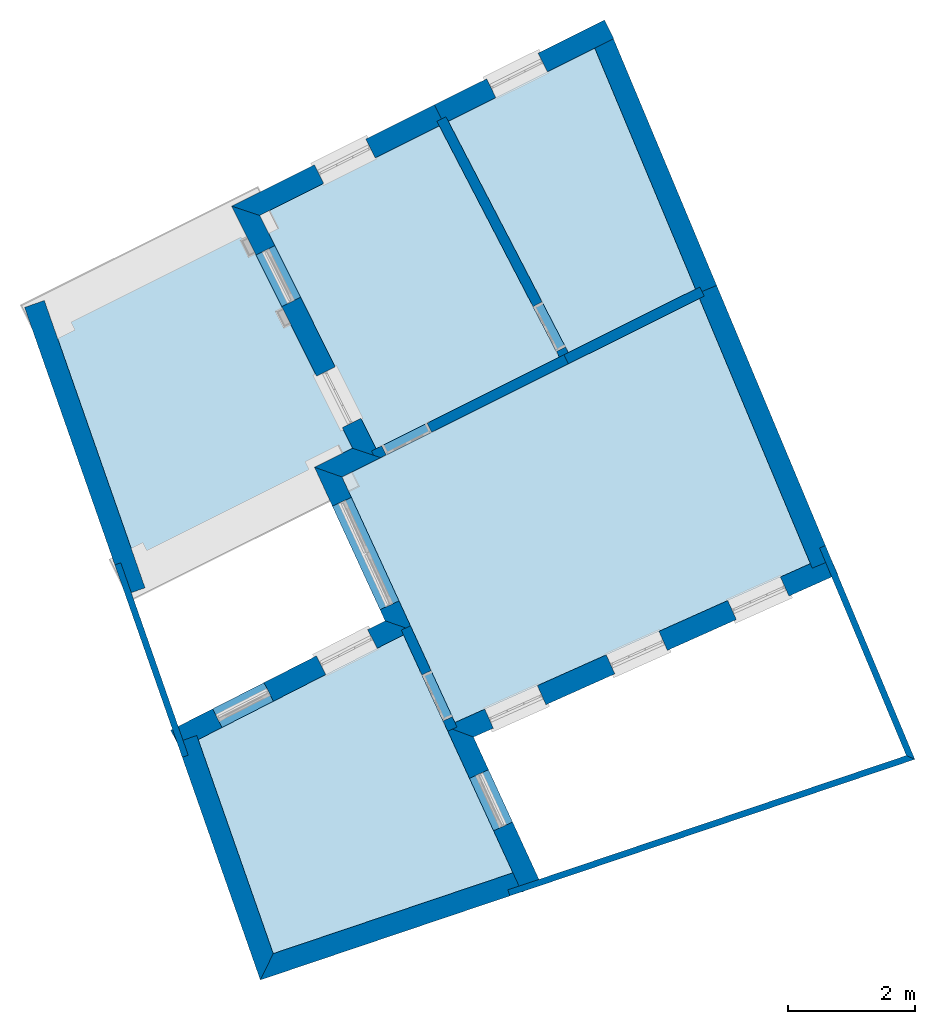
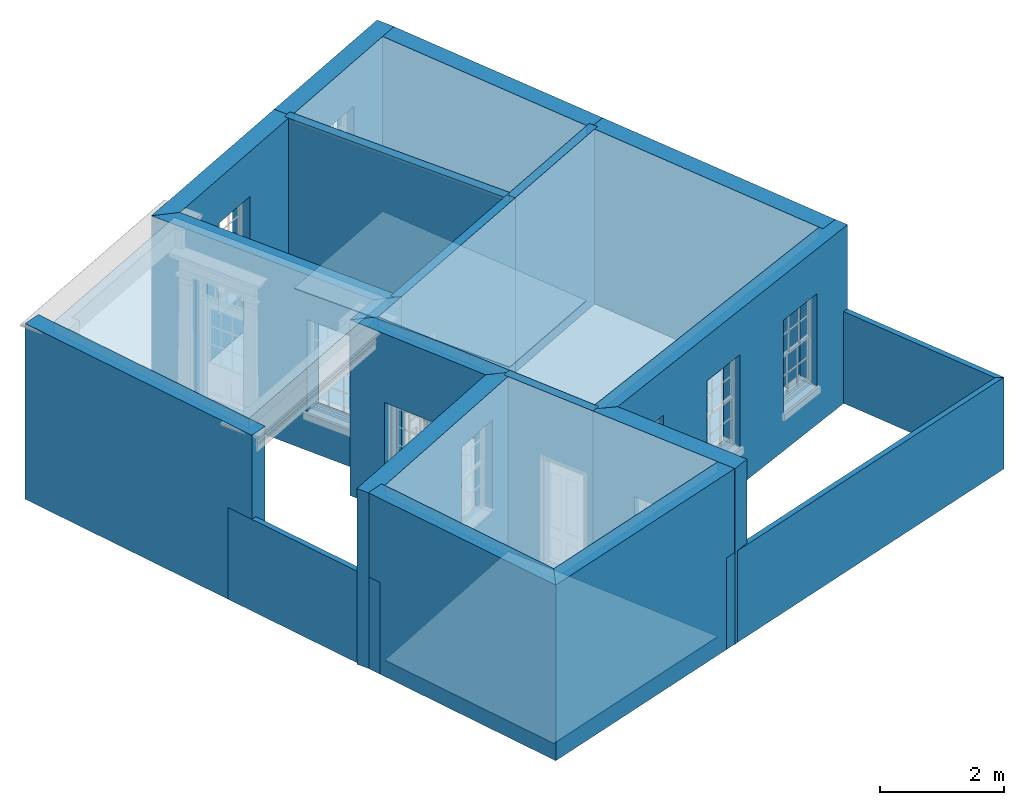
# One storey, part 1 of 10: 20 walls, 8 slabs, 14 openings.
"""IFC2X3 building model written with IfcOpenShell, lengths in metres."""

import ifcopenshell
import ifcopenshell.guid

model = None  # the IFC model being written
_history = None  # IfcOwnerHistory: only IFC2X3 demands one
_inside = {}  # id of a spatial element -> (the spatial element, [elements in it])
_under = {}  # id of a project, library or spatial element -> (it, [spatial elements below it])
_declared = {}  # id of a project -> (the project, [libraries it declares])
_typed = {}  # id of a type object -> (the type object, [elements of that type])
_made_of = {}  # id of a material, layer set ... -> (it, [elements and type objects made of it])


def new_model(schema):
    """Start an empty IFC model of exactly this schema.

    Asked for "IFC4X3", IfcOpenShell would pick the latest addendum, in which some entities
    have other attributes; the version numbers below select the first issue.
    IFC2X3 requires an IfcOwnerHistory on every rooted entity: one is made here for all.
    """
    global model, _history
    if schema == "IFC4X3":
        model = ifcopenshell.file(schema_version=(4, 3, 0, 0))
    else:
        model = ifcopenshell.file(schema=schema)
    _inside.clear()
    _under.clear()
    _declared.clear()
    _typed.clear()
    _made_of.clear()
    _history = None
    if model.schema == "IFC2X3":
        org = make("IfcOrganization", Name="unknown")
        user = make(
            "IfcPersonAndOrganization",
            ThePerson=make("IfcPerson", FamilyName="unknown"),
            TheOrganization=org,
        )
        app = make(
            "IfcApplication",
            ApplicationDeveloper=org,
            Version="unknown",
            ApplicationFullName="unknown",
            ApplicationIdentifier="unknown",
        )
        _history = make(
            "IfcOwnerHistory",
            OwningUser=user,
            OwningApplication=app,
            ChangeAction="ADDED",
            CreationDate=0,
        )
    return model


def make(cls, **values):
    """One entity of the class cls with the attributes given. An attribute that is None is left unset."""
    return model.create_entity(
        cls, **{name: value for name, value in values.items() if value is not None}
    )


def rooted(cls, **values):
    """An entity with a GlobalId (a new one), such as an element, a storey or a relation."""
    return make(cls, GlobalId=ifcopenshell.guid.new(), OwnerHistory=_history, **values)


def si_unit(unit_type, name, prefix=None):
    """IfcSIUnit, for example si_unit("LENGTHUNIT", "METRE", prefix="MILLI")."""
    return make("IfcSIUnit", UnitType=unit_type, Prefix=prefix, Name=name)


def assignment(units):
    """IfcUnitAssignment: the units of a project."""
    return None if units is None else make("IfcUnitAssignment", Units=units)


def point(xyz):
    """IfcCartesianPoint."""
    return None if xyz is None else make("IfcCartesianPoint", Coordinates=xyz)


def direction(xyz):
    """IfcDirection."""
    return None if xyz is None else make("IfcDirection", DirectionRatios=xyz)


def frame(location, z_axis=None, x_axis=None):
    """IfcAxis2Placement3D, a coordinate frame: its origin and axes. An axis left out is left unset."""
    return make(
        "IfcAxis2Placement3D",
        Location=point(location),
        Axis=direction(z_axis),
        RefDirection=direction(x_axis),
    )


def origin():
    """The frame at (0, 0, 0) with its axes left unset."""
    return frame((0.0, 0.0, 0.0))


def place(relative_to, where):
    """IfcLocalPlacement: puts the frame where relative to a parent placement (None: the world)."""
    return make(
        "IfcLocalPlacement", PlacementRelTo=relative_to, RelativePlacement=where
    )


def context(
    kind, dimensions, precision=None, world=None, true_north=None, identifier=None
):
    """IfcGeometricRepresentationContext, for example the 3D "Model" context."""
    return make(
        "IfcGeometricRepresentationContext",
        ContextIdentifier=identifier,
        ContextType=kind,
        CoordinateSpaceDimension=dimensions,
        Precision=precision,
        WorldCoordinateSystem=world,
        TrueNorth=true_north,
    )


def subcontext(parent, identifier, kind, view, scale=None):
    """IfcGeometricRepresentationSubContext, for example "Body" below "Model"."""
    return make(
        "IfcGeometricRepresentationSubContext",
        ContextIdentifier=identifier,
        ContextType=kind,
        ParentContext=parent,
        TargetScale=scale,
        TargetView=view,
    )


def project(units=None, contexts=None):
    """IfcProject with its units and contexts."""
    return rooted(
        "IfcProject",
        Name="project",
        RepresentationContexts=contexts,
        UnitsInContext=assignment(units),
    )


def spatial(cls, under=None, at=None, **own):
    """A site, building, storey or space (cls), placed at a placement, below another one or the project."""
    s = rooted(cls, ObjectPlacement=at, **own)
    if under is not None:
        _under.setdefault(under.id(), (under, []))[1].append(s)
    return s


def polyline(points):
    """IfcPolyline through the points."""
    return make("IfcPolyline", Points=[point(p) for p in points])


def outline(outer, holes=None, kind="AREA"):
    """IfcArbitraryClosedProfileDef: a profile drawn as a closed curve; with holes, ...WithVoids."""
    if holes is None:
        return make("IfcArbitraryClosedProfileDef", ProfileType=kind, OuterCurve=outer)
    return make(
        "IfcArbitraryProfileDefWithVoids",
        ProfileType=kind,
        OuterCurve=outer,
        InnerCurves=holes,
    )


def extrude(swept, where, along, depth):
    """IfcExtrudedAreaSolid: the profile swept, set in the frame where, extruded along a direction by depth."""
    return make(
        "IfcExtrudedAreaSolid",
        SweptArea=swept,
        Position=where,
        ExtrudedDirection=direction(along),
        Depth=depth,
    )


def shape(context_of_items, identifier, shape_type, items):
    """IfcShapeRepresentation: the items that make up one representation, for example the "Body"."""
    return make(
        "IfcShapeRepresentation",
        ContextOfItems=context_of_items,
        RepresentationIdentifier=identifier,
        RepresentationType=shape_type,
        Items=items,
    )


def material(Name=None, Category=None):
    """IfcMaterial."""
    return make("IfcMaterial", Name=Name, Category=Category)


def layer(
    of_material, thickness, ventilated=None, Name=None, Category=None, Priority=None
):
    """IfcMaterialLayer: one layer of a wall or slab, of a material (None: an air gap)."""
    return make(
        "IfcMaterialLayer",
        Material=of_material,
        LayerThickness=thickness,
        IsVentilated=ventilated,
        Name=Name,
        Category=Category,
        Priority=Priority,
    )


def layer_set(layers, Name=None):
    """IfcMaterialLayerSet."""
    return make("IfcMaterialLayerSet", MaterialLayers=layers, LayerSetName=Name)


def layer_usage(for_layer_set, set_direction, sense, offset, extent=None):
    """IfcMaterialLayerSetUsage: how a layer set lies in its element."""
    return make(
        "IfcMaterialLayerSetUsage",
        ForLayerSet=for_layer_set,
        LayerSetDirection=set_direction,
        DirectionSense=sense,
        OffsetFromReferenceLine=offset,
        ReferenceExtent=extent,
    )


def made_of(thing, what):
    """Note that an element or type object is made of a material, layer set ...; save() writes the relation."""
    if what is not None:
        _made_of.setdefault(what.id(), (what, []))[1].append(thing)
    return thing


def element(
    cls,
    number,
    at=None,
    inside=None,
    cuts=None,
    type_object=None,
    material=None,
    context=None,
    identifier="Body",
    shape_type=None,
    held_by="IfcProductDefinitionShape",
    body=None,
    shapes=None,
    **own,
):
    """One element of the class cls, such as IfcWall. Its Tag is "e" and its number.

    at: its placement. inside: the storey or other place that contains it. cuts: it is an
    opening in that element (IfcRelVoidsElement). A single representation is given by context,
    identifier, shape_type and body (its items); several are given by shapes. held_by: the class
    of the entity that holds the representations. save() writes the other relations.
    """
    e = rooted(cls, Tag="e%d" % number, ObjectPlacement=at, **own)
    if body is not None:
        shapes = [shape(context, identifier, shape_type, body)]
    if shapes is not None:
        e.Representation = make(held_by, Representations=shapes)
    if inside is not None:
        _inside.setdefault(inside.id(), (inside, []))[1].append(e)
    if cuts is not None:
        rooted(
            "IfcRelVoidsElement", RelatingBuildingElement=cuts, RelatedOpeningElement=e
        )
    if type_object is not None:
        _typed.setdefault(type_object.id(), (type_object, []))[1].append(e)
    return made_of(e, material)


def aggregate(whole, parts):
    """IfcRelAggregates: a whole, such as a stair, and the parts it consists of."""
    return rooted("IfcRelAggregates", RelatingObject=whole, RelatedObjects=parts)


def save(model, path):
    """Write the relations noted so far, then the file.

    IfcRelAggregates (storeys below a building ...), IfcRelContainedInSpatialStructure (elements
    in a storey), IfcRelDefinesByType, IfcRelAssociatesMaterial and IfcRelDeclares: one each for
    every whole, place, type object, material and project.
    """
    for whole, parts in _under.values():
        aggregate(whole, parts)
    for where, things in _inside.values():
        rooted(
            "IfcRelContainedInSpatialStructure",
            RelatedElements=things,
            RelatingStructure=where,
        )
    for kind, things in _typed.values():
        rooted("IfcRelDefinesByType", RelatedObjects=things, RelatingType=kind)
    for what, things in _made_of.values():
        rooted("IfcRelAssociatesMaterial", RelatedObjects=things, RelatingMaterial=what)
    for by, libraries in _declared.values():
        rooted("IfcRelDeclares", RelatingContext=by, RelatedDefinitions=libraries)
    model.write(path)


model = new_model("IFC2X3")

# Units and contexts
model_context = context("Model", 3, world=origin())
body_context = subcontext(model_context, "Body", "Model", "MODEL_VIEW")
ifc_project = project(units=[si_unit("PLANEANGLEUNIT", "RADIAN"), si_unit("MASSUNIT", "GRAM", prefix="KILO"), si_unit("FORCEUNIT", "NEWTON", prefix="KILO"), si_unit("LENGTHUNIT", "METRE")], contexts=[model_context])

# Site, building, storey
site_placement = place(None, origin())
site = spatial("IfcSite", under=ifc_project, at=site_placement, CompositionType="ELEMENT")
building_placement = place(None, origin())
building = spatial("IfcBuilding", under=site, at=building_placement, Name="Building plot-8", CompositionType="ELEMENT")
storey_placement = place(None, origin())
storey = spatial("IfcBuildingStorey", under=building, at=storey_placement, Name="Floor 0", CompositionType="ELEMENT", Elevation=0.0)

# Slabs
slab_1_placement = place(storey_placement, frame((0.0, 0.0, 3.25)))
element("IfcSlab", 1, at=slab_1_placement, inside=storey, Name="Slab", ObjectType="Slab", PredefinedType="FLOOR", context=body_context, shape_type="SweptSolid", body=[
    extrude(outline(polyline([(31.3024320418341, 11.6441148215606), (29.5509227560087, 15.8319749374872), (23.9047363507031, 13.0131514717753), (25.6887883842839, 9.13469885839309), (31.3024320418341, 11.6441148215606)])), origin(), (0.0, 0.0, 1.0), 0.2),
])
slab_2_placement = place(storey_placement, frame((0.0, 0.0, 3.25)))
element("IfcSlab", 2, at=slab_2_placement, inside=storey, Name="Slab", ObjectType="Slab", PredefinedType="FLOOR", context=body_context, shape_type="SweptSolid", body=[
    extrude(outline(polyline([(27.480706150414, 14.9772635263), (29.4890486291312, 15.9799160247855), (27.8974321953213, 19.7854722025051), (25.5844795437758, 18.6307449687159), (27.480706150414, 14.9772635263)])), origin(), (0.0, 0.0, 1.0), 0.2),
])
slab_3_placement = place(storey_placement, frame((0.0, 0.0, 3.25)))
element("IfcSlab", 3, at=slab_3_placement, inside=storey, Name="Slab", ObjectType="Slab", PredefinedType="FLOOR", context=body_context, shape_type="SweptSolid", body=[
    extrude(outline(polyline([(26.6046679992445, 6.76074786941378), (24.8762350878957, 10.5182868962446), (21.6342182414283, 8.86422730042999), (22.8188411576789, 5.48440733819155), (26.6046679992445, 6.76074786941378)])), origin(), (0.0, 0.0, 1.0), 0.2),
])
slab_4_placement = place(storey_placement, frame((0.0, 0.0, 3.25)))
element("IfcSlab", 4, at=slab_4_placement, inside=storey, Name="Slab", ObjectType="Slab", PredefinedType="FLOOR", context=body_context, shape_type="SweptSolid", body=[
    extrude(outline(polyline([(22.4618389824098, 17.0717860790321), (19.3091498419461, 15.4978256230182), (20.6813816740663, 11.5827430466167), (24.3002316620791, 13.3894314080773), (22.4618389824098, 17.0717860790321)])), origin(), (0.0, 0.0, 1.0), 0.2),
])
slab_5_placement = place(storey_placement, origin())
element("IfcSlab", 5, at=slab_5_placement, inside=storey, Name="Slab", ObjectType="Slab", PredefinedType="FLOOR", context=body_context, shape_type="SweptSolid", body=[
    extrude(outline(polyline([(31.3024320418341, 11.6441148215606), (29.5509227560087, 15.8319749374872), (23.9047363507031, 13.0131514717753), (25.6887883842839, 9.13469885839309), (31.3024320418341, 11.6441148215606)])), origin(), (0.0, 0.0, 1.0), 0.02),
])
slab_6_placement = place(storey_placement, origin())
element("IfcSlab", 6, at=slab_6_placement, inside=storey, Name="Slab", ObjectType="Slab", PredefinedType="FLOOR", context=body_context, shape_type="SweptSolid", body=[
    extrude(outline(polyline([(27.480706150414, 14.9772635263), (29.4890486291312, 15.9799160247855), (27.8974321953213, 19.7854722025051), (25.5844795437758, 18.6307449687159), (27.480706150414, 14.9772635263)])), origin(), (0.0, 0.0, 1.0), 0.02),
])
slab_7_placement = place(storey_placement, origin())
element("IfcSlab", 7, at=slab_7_placement, inside=storey, Name="Slab", ObjectType="Slab", PredefinedType="FLOOR", context=body_context, shape_type="SweptSolid", body=[
    extrude(outline(polyline([(26.6046679992445, 6.76074786941378), (24.8762350878957, 10.5182868962446), (21.6342182414283, 8.86422730042999), (22.8188411576789, 5.48440733819155), (26.6046679992445, 6.76074786941378)])), origin(), (0.0, 0.0, 1.0), 0.02),
])
slab_8_placement = place(storey_placement, origin())
element("IfcSlab", 8, at=slab_8_placement, inside=storey, Name="Slab", ObjectType="Slab", PredefinedType="FLOOR", context=body_context, shape_type="SweptSolid", body=[
    extrude(outline(polyline([(24.4433832878594, 13.4608989674064), (27.3375368702061, 14.9057871531076), (25.4413102635679, 18.5592685955235), (22.6049906081901, 17.1432536383612), (24.4433832878594, 13.4608989674064)])), origin(), (0.0, 0.0, 1.0), 0.02),
])

# Wall, opening
ifc_material_1 = material(Name="Masonry")
ifc_layer_1 = layer(ifc_material_1, 0.33, ventilated=False)
ifc_layer_set_1 = layer_set([ifc_layer_1], Name="My Wall")
ifc_layer_usage_1 = layer_usage(ifc_layer_set_1, "AXIS2", "NEGATIVE", 0.08)
wall_1_placement = place(storey_placement, origin())
wall_1 = element("IfcWallStandardCase", 9, at=wall_1_placement, inside=storey, material=ifc_layer_usage_1, Name="exterior", context=body_context, shape_type="SweptSolid", body=[
    extrude(outline(polyline([(26.7463189204902, 6.45280484121041), (27.0461218313343, 6.59071138438159), (25.9819110894624, 8.90425989939787), (25.5427100949966, 9.06939881204675), (26.7463189204902, 6.45280484121041)])), origin(), (0.0, 0.0, 1.0), 3.45),
])
opening_1_placement = place(storey_placement, frame((0.0, 0.0, 0.02)))
element("IfcOpeningElement", 10, at=opening_1_placement, cuts=wall_1, Name="Opening", ObjectType="Opening", context=body_context, shape_type="SweptSolid", body=[
    extrude(outline(polyline([(26.5991206991673, 7.56247267643206), (26.2188329589074, 8.3892019154263), (25.9190300480633, 8.25129537225511), (26.2993177883233, 7.42456613326087), (26.5991206991673, 7.56247267643206)])), origin(), (0.0, 0.0, 1.0), 2.08),
])

# Wall, openings
wall_2_placement = place(storey_placement, origin())
wall_2 = element("IfcWallStandardCase", 11, at=wall_2_placement, inside=storey, material=ifc_layer_usage_1, Name="exterior", context=body_context, shape_type="SweptSolid", body=[
    extrude(outline(polyline([(25.5427100949966, 9.06939881204675), (25.9819110894624, 8.90425989939787), (31.7366248764663, 11.4767371568641), (31.6019513234471, 11.778006196291), (25.5427100949966, 9.06939881204675)])), origin(), (0.0, 0.0, 1.0), 3.45),
])
opening_2_placement = place(storey_placement, frame((0.0, 0.0, 0.75)))
element("IfcOpeningElement", 12, at=opening_2_placement, cuts=wall_2, Name="Opening", ObjectType="Opening", context=body_context, shape_type="SweptSolid", body=[
    extrude(outline(polyline([(26.2953527613871, 9.04437487338484), (27.1261249610187, 9.41574739837715), (26.9914514079996, 9.71701643780401), (26.1606792083679, 9.34564391281171), (26.2953527613871, 9.04437487338484)])), origin(), (0.0, 0.0, 1.0), 1.82),
])
opening_3_placement = place(storey_placement, frame((0.0, 0.0, 0.75)))
element("IfcOpeningElement", 13, at=opening_3_placement, cuts=wall_2, Name="Opening", ObjectType="Opening", context=body_context, shape_type="SweptSolid", body=[
    extrude(outline(polyline([(28.2144135191812, 9.90223511419651), (29.0451857188129, 10.2736076391888), (28.9105121657937, 10.5748766786157), (28.0797399661621, 10.2035041536234), (28.2144135191812, 9.90223511419651)])), origin(), (0.0, 0.0, 1.0), 1.82),
])
opening_4_placement = place(storey_placement, frame((0.0, 0.0, 0.75)))
element("IfcOpeningElement", 14, at=opening_4_placement, cuts=wall_2, Name="Opening", ObjectType="Opening", context=body_context, shape_type="SweptSolid", body=[
    extrude(outline(polyline([(30.1334742769754, 10.7600953550082), (30.9642464766071, 11.1314678800005), (30.8295729235879, 11.4327369194274), (29.9988007239562, 11.0613643944351), (30.1334742769754, 10.7600953550082)])), origin(), (0.0, 0.0, 1.0), 1.82),
])

# Wall, opening
wall_3_placement = place(storey_placement, origin())
wall_3 = element("IfcWallStandardCase", 15, at=wall_3_placement, inside=storey, material=ifc_layer_usage_1, Name="exterior", context=body_context, shape_type="SweptSolid", body=[
    extrude(outline(polyline([(28.1976396877446, 19.9353489269842), (28.0502378466283, 20.230599155156), (25.3643689149095, 18.889695786567), (25.5117707560258, 18.5944455583952), (28.1976396877446, 19.9353489269842)])), origin(), (0.0, 0.0, 1.0), 3.45),
])
opening_5_placement = place(storey_placement, frame((0.0, 0.0, 0.75)))
element("IfcOpeningElement", 16, at=opening_5_placement, cuts=wall_3, Name="Opening", ObjectType="Opening", context=body_context, shape_type="SweptSolid", body=[
    extrude(outline(polyline([(27.0025536089408, 19.7075493119778), (26.1883787373153, 19.3010775682935), (26.3357805784316, 19.0058273401217), (27.149955450057, 19.4122990838059), (27.0025536089408, 19.7075493119778)])), origin(), (0.0, 0.0, 1.0), 1.82),
])

wall_4_placement = place(storey_placement, origin())
wall_4 = element("IfcWallStandardCase", 17, at=wall_4_placement, inside=storey, material=ifc_layer_usage_1, Name="exterior", context=body_context, shape_type="SweptSolid", body=[
    extrude(outline(polyline([(25.5117707560258, 18.5944455583952), (25.3643689149095, 18.889695786567), (22.162338538902, 17.2911020254168), (22.6049906081901, 17.1432536383612), (25.5117707560258, 18.5944455583952)])), origin(), (0.0, 0.0, 1.0), 3.45),
])
opening_6_placement = place(storey_placement, frame((0.0, 0.0, 0.75)))
element("IfcOpeningElement", 18, at=opening_6_placement, cuts=wall_4, Name="Opening", ObjectType="Opening", context=body_context, shape_type="SweptSolid", body=[
    extrude(outline(polyline([(24.2822783703593, 18.3494688085599), (23.4681034987339, 17.9429970648756), (23.6155053398501, 17.6477468367038), (24.4296802114756, 18.054218580388), (24.2822783703593, 18.3494688085599)])), origin(), (0.0, 0.0, 1.0), 1.82),
])

# Wall, openings
wall_5_placement = place(storey_placement, origin())
wall_5 = element("IfcWallStandardCase", 19, at=wall_5_placement, inside=storey, material=ifc_layer_usage_1, Name="exterior", context=body_context, shape_type="SweptSolid", body=[
    extrude(outline(polyline([(22.6049906081901, 17.1432536383612), (22.162338538902, 17.2911020254168), (24.0721987779004, 13.4655957286817), (24.5148508471885, 13.3177473416261), (22.6049906081901, 17.1432536383612)])), origin(), (0.0, 0.0, 1.0), 3.45),
])
opening_7_placement = place(storey_placement, frame((0.0, 0.0, 0.02)))
element("IfcOpeningElement", 20, at=opening_7_placement, cuts=wall_5, Name="Opening", ObjectType="Opening", context=body_context, shape_type="SweptSolid", body=[
    extrude(outline(polyline([(22.5482357882612, 16.518138471764), (22.9547075319454, 15.7039636001386), (23.2499577601173, 15.8513654412549), (22.843486016433, 16.6655403128803), (22.5482357882612, 16.518138471764)])), origin(), (0.0, 0.0, 1.0), 2.545),
])
opening_8_placement = place(storey_placement, frame((0.0, 0.0, 0.75)))
element("IfcOpeningElement", 21, at=opening_8_placement, cuts=wall_5, Name="Opening", ObjectType="Opening", context=body_context, shape_type="SweptSolid", body=[
    extrude(outline(polyline([(23.5031659077604, 14.6053853233965), (23.9096376514446, 13.791210451771), (24.2048878796165, 13.9386122928873), (23.7984161359322, 14.7527871645127), (23.5031659077604, 14.6053853233965)])), origin(), (0.0, 0.0, 1.0), 1.82),
])

# Wall
wall_6_placement = place(storey_placement, origin())
element("IfcWallStandardCase", 22, at=wall_6_placement, inside=storey, material=ifc_layer_usage_1, Name="exterior", context=body_context, shape_type="SweptSolid", body=[
    extrude(outline(polyline([(24.5148508471885, 13.3177473416261), (24.0721987779004, 13.4655957286817), (23.4713589357303, 13.1656301723458), (23.9047363507031, 13.0131514717753), (24.5148508471885, 13.3177473416261)])), origin(), (0.0, 0.0, 1.0), 3.45),
])

# Wall, opening
wall_7_placement = place(storey_placement, origin())
wall_7 = element("IfcWallStandardCase", 23, at=wall_7_placement, inside=storey, material=ifc_layer_usage_1, Name="exterior", context=body_context, shape_type="SweptSolid", body=[
    extrude(outline(polyline([(23.9047363507031, 13.0131514717753), (23.4713589357303, 13.1656301723458), (24.5866593596622, 10.7410148794705), (25.0188753029837, 10.5910611684611), (23.9047363507031, 13.0131514717753)])), origin(), (0.0, 0.0, 1.0), 3.45),
])
opening_9_placement = place(storey_placement, frame((0.0, 0.0, 0.02)))
element("IfcOpeningElement", 24, at=opening_9_placement, cuts=wall_7, Name="Opening", ObjectType="Opening", context=body_context, shape_type="SweptSolid", body=[
    extrude(outline(polyline([(23.7536532483681, 12.5519344426335), (24.5058707565745, 10.9166458380295), (24.8056736674186, 11.0545523812007), (24.0534561592121, 12.6898409858047), (23.7536532483681, 12.5519344426335)])), origin(), (0.0, 0.0, 1.0), 2.08),
])

# Wall, openings
wall_8_placement = place(storey_placement, origin())
wall_8 = element("IfcWallStandardCase", 25, at=wall_8_placement, inside=storey, material=ifc_layer_usage_1, Name="exterior", context=body_context, shape_type="SweptSolid", body=[
    extrude(outline(polyline([(25.0188753029837, 10.5910611684611), (24.5866593596622, 10.7410148794705), (21.1992955616312, 9.01280004901607), (21.3492685706448, 8.71884750766391), (25.0188753029837, 10.5910611684611)])), origin(), (0.0, 0.0, 1.0), 3.45),
])
opening_10_placement = place(storey_placement, frame((0.0, 0.0, 1.05)))
element("IfcOpeningElement", 26, at=opening_10_placement, cuts=wall_8, Name="Opening", ObjectType="Opening", context=body_context, shape_type="SweptSolid", body=[
    extrude(outline(polyline([(24.3105588621873, 10.6001498874347), (23.4999624602768, 10.186587953488), (23.6499354692904, 9.89263541213587), (24.4605318712009, 10.3061973460826), (24.3105588621873, 10.6001498874347)])), origin(), (0.0, 0.0, 1.0), 1.82),
])
opening_11_placement = place(storey_placement, frame((0.0, 0.0, 0.02)))
element("IfcOpeningElement", 27, at=opening_11_placement, cuts=wall_8, Name="Opening", ObjectType="Opening", context=body_context, shape_type="SweptSolid", body=[
    extrude(outline(polyline([(22.6719083026935, 9.76411916628935), (21.861311900783, 9.35055723234263), (22.0112849097966, 9.05660469099047), (22.8218813117071, 9.47016662493719), (22.6719083026935, 9.76411916628935)])), origin(), (0.0, 0.0, 1.0), 2.08),
])

# Walls
wall_9_placement = place(storey_placement, origin())
element("IfcWallStandardCase", 28, at=wall_9_placement, inside=storey, material=ifc_layer_usage_1, Name="party", context=body_context, shape_type="SweptSolid", body=[
    extrude(outline(polyline([(21.6110997154158, 8.93018622680435), (21.2996749259473, 8.82103220486982), (22.615273773042, 5.0675278747479), (22.8188411576789, 5.48440733819155), (21.6110997154158, 8.93018622680435)])), origin(), (0.0, 0.0, 1.0), 3.45),
])
wall_10_placement = place(storey_placement, origin())
element("IfcWallStandardCase", 29, at=wall_10_placement, inside=storey, material=ifc_layer_usage_1, Name="party", context=body_context, shape_type="SweptSolid", body=[
    extrude(outline(polyline([(22.8188411576789, 5.48440733819155), (22.615273773042, 5.0675278747479), (26.7943911165685, 6.4764610017767), (26.6889662060441, 6.78916787448804), (22.8188411576789, 5.48440733819155)])), origin(), (0.0, 0.0, 1.0), 3.45),
])
wall_11_placement = place(storey_placement, origin())
element("IfcWallStandardCase", 30, at=wall_11_placement, inside=storey, material=ifc_layer_usage_1, Name="party", context=body_context, shape_type="SweptSolid", body=[
    extrude(outline(polyline([(31.3325603412757, 11.5720780332814), (31.6370059475429, 11.6994078130841), (29.8223626642942, 16.0382213678007), (29.517917058027, 15.910891587998), (31.3325603412757, 11.5720780332814)])), origin(), (0.0, 0.0, 1.0), 3.45),
])
wall_12_placement = place(storey_placement, origin())
element("IfcWallStandardCase", 31, at=wall_12_placement, inside=storey, material=ifc_layer_usage_1, Name="party", context=body_context, shape_type="SweptSolid", body=[
    extrude(outline(polyline([(29.517917058027, 15.910891587998), (29.8223626642942, 16.0382213678007), (28.1688721036068, 19.9917186328186), (27.8644264973396, 19.8643888530159), (29.517917058027, 15.910891587998)])), origin(), (0.0, 0.0, 1.0), 3.45),
])

# Wall, opening
ifc_material_2 = material(Name="Masonry")
ifc_layer_2 = layer(ifc_material_2, 0.16, ventilated=False)
ifc_layer_set_2 = layer_set([ifc_layer_2], Name="My Wall")
ifc_layer_usage_2 = layer_usage(ifc_layer_set_2, "AXIS2", "NEGATIVE", 0.08)
wall_13_placement = place(storey_placement, origin())
wall_13 = element("IfcWallStandardCase", 32, at=wall_13_placement, inside=storey, material=ifc_layer_usage_2, Name="interior", context=body_context, shape_type="SweptSolid", body=[
    extrude(outline(polyline([(27.4817132172852, 14.7989349376481), (27.4102456579562, 14.9420865634283), (24.3718074749693, 13.4251651877418), (24.4432750342983, 13.2820135619616), (27.4817132172852, 14.7989349376481)])), origin(), (0.0, 0.0, 1.0), 3.45),
])
opening_12_placement = place(storey_placement, frame((0.0, 0.0, 0.02)))
element("IfcOpeningElement", 33, at=opening_12_placement, cuts=wall_13, Name="Opening", ObjectType="Opening", context=body_context, shape_type="SweptSolid", body=[
    extrude(outline(polyline([(25.2486111828736, 13.8629039886326), (24.5328530539721, 13.5055661919871), (24.6043206133012, 13.3624145662068), (25.3200787422027, 13.7197523628523), (25.2486111828736, 13.8629039886326)])), origin(), (0.0, 0.0, 1.0), 2.1),
])

wall_14_placement = place(storey_placement, origin())
wall_14 = element("IfcWallStandardCase", 34, at=wall_14_placement, inside=storey, material=ifc_layer_usage_2, Name="interior", context=body_context, shape_type="SweptSolid", body=[
    extrude(outline(polyline([(25.5765035698139, 8.99593324699947), (25.7218625568899, 9.06279702550671), (24.9867751738983, 10.6608454725049), (24.8414161868223, 10.5939816939977), (25.5765035698139, 8.99593324699947)])), origin(), (0.0, 0.0, 1.0), 3.45),
])
opening_13_placement = place(storey_placement, frame((0.0, 0.0, 0.02)))
element("IfcOpeningElement", 35, at=opening_13_placement, cuts=wall_14, Name="Opening", ObjectType="Opening", context=body_context, shape_type="SweptSolid", body=[
    extrude(outline(polyline([(25.6466408060692, 9.22632588596711), (25.312321913533, 9.95312082134665), (25.1669629264571, 9.8862570428394), (25.5012818189933, 9.15946210745986), (25.6466408060692, 9.22632588596711)])), origin(), (0.0, 0.0, 1.0), 2.1),
])

wall_15_placement = place(storey_placement, origin())
wall_15 = element("IfcWallStandardCase", 36, at=wall_15_placement, inside=storey, material=ifc_layer_usage_2, Name="interior", context=body_context, shape_type="SweptSolid", body=[
    extrude(outline(polyline([(27.374973605375, 14.8336573682362), (27.5169852698664, 14.9073641328402), (25.5470428086069, 18.7028747535873), (25.4050311441155, 18.6291679889833), (27.374973605375, 14.8336573682362)])), origin(), (0.0, 0.0, 1.0), 3.45),
])
opening_14_placement = place(storey_placement, frame((0.0, 0.0, 0.02)))
element("IfcOpeningElement", 37, at=opening_14_placement, cuts=wall_15, Name="Opening", ObjectType="Opening", context=body_context, shape_type="SweptSolid", body=[
    extrude(outline(polyline([(27.4340651596868, 15.067127255393), (27.0655313366665, 15.7771855778497), (26.9235196721751, 15.7034788132456), (27.2920534951955, 14.9934204907889), (27.4340651596868, 15.067127255393)])), origin(), (0.0, 0.0, 1.0), 2.1),
])

# Walls
wall_16_placement = place(storey_placement, origin())
element("IfcWallStandardCase", 38, at=wall_16_placement, inside=storey, material=ifc_layer_usage_2, Name="interior", context=body_context, shape_type="SweptSolid", body=[
    extrude(outline(polyline([(27.4102456579561, 14.9420865634283), (27.4817132172853, 14.7989349376481), (29.6274558331503, 15.8701836005146), (29.5559882738211, 16.0133352262948), (27.4102456579561, 14.9420865634283)])), origin(), (0.0, 0.0, 1.0), 3.45),
])
wall_17_placement = place(storey_placement, origin())
element("IfcWallStandardCase", 39, at=wall_17_placement, inside=storey, material=ifc_layer_usage_1, Name="party", context=body_context, shape_type="SweptSolid", body=[
    extrude(outline(polyline([(19.2031344831521, 15.8002955660189), (18.8917096936836, 15.6911415440844), (20.4826719527699, 11.1520042974011), (20.7940967422384, 11.2611583193356), (19.2031344831521, 15.8002955660189)])), origin(), (0.0, 0.0, 1.0), 3.45),
])
ifc_material_3 = material(Name="Masonry")
ifc_layer_3 = layer(ifc_material_3, 0.1, ventilated=False)
ifc_layer_set_3 = layer_set([ifc_layer_3], Name="My Wall")
ifc_layer_usage_3 = layer_usage(ifc_layer_set_3, "AXIS2", "NEGATIVE", -0.15)
wall_18_placement = place(storey_placement, origin())
element("IfcWallStandardCase", 40, at=wall_18_placement, inside=storey, material=ifc_layer_usage_3, Name="fence", context=body_context, shape_type="SweptSolid", body=[
    extrude(outline(polyline([(20.4116582193747, 11.6569370153639), (20.3172870710509, 11.6238600390201), (21.3823673668068, 8.58510433406033), (21.4767385151306, 8.61818131040413), (20.4116582193747, 11.6569370153639)])), origin(), (0.0, 0.0, 1.0), 1.8),
])
wall_19_placement = place(storey_placement, origin())
element("IfcWallStandardCase", 41, at=wall_19_placement, inside=storey, material=ifc_layer_usage_3, Name="fence", context=body_context, shape_type="SweptSolid", body=[
    extrude(outline(polyline([(26.5255450279919, 6.49135330371614), (26.5574919705751, 6.39659364531876), (32.9530410281361, 8.55276687330758), (32.8193601935888, 8.61322832020538), (26.5255450279919, 6.49135330371614)])), origin(), (0.0, 0.0, 1.0), 1.8),
])
wall_20_placement = place(storey_placement, origin())
element("IfcWallStandardCase", 42, at=wall_20_placement, inside=storey, material=ifc_layer_usage_3, Name="fence", context=body_context, shape_type="SweptSolid", body=[
    extrude(outline(polyline([(32.8193601935888, 8.61322832020538), (32.9530410281361, 8.55276687330758), (31.5405439931468, 11.9300484238926), (31.4482877488234, 11.8914636421342), (32.8193601935888, 8.61322832020538)])), origin(), (0.0, 0.0, 1.0), 1.8),
])

save(model, "model.ifc")
